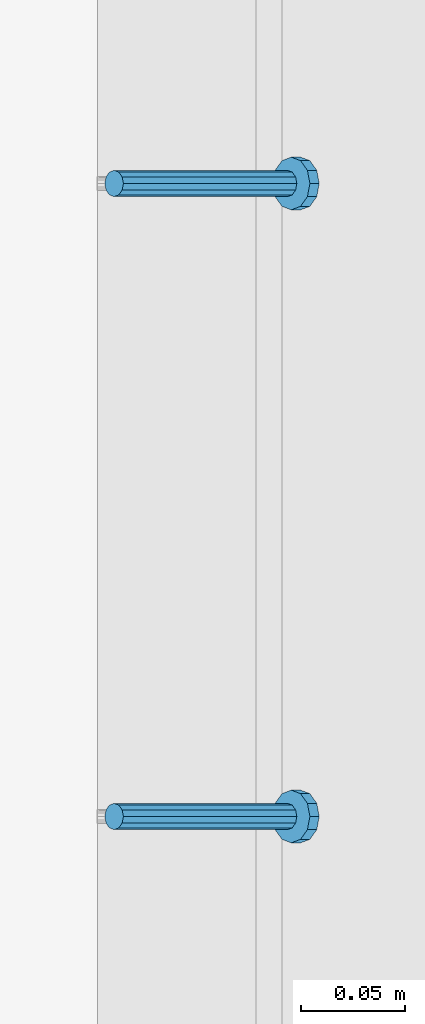
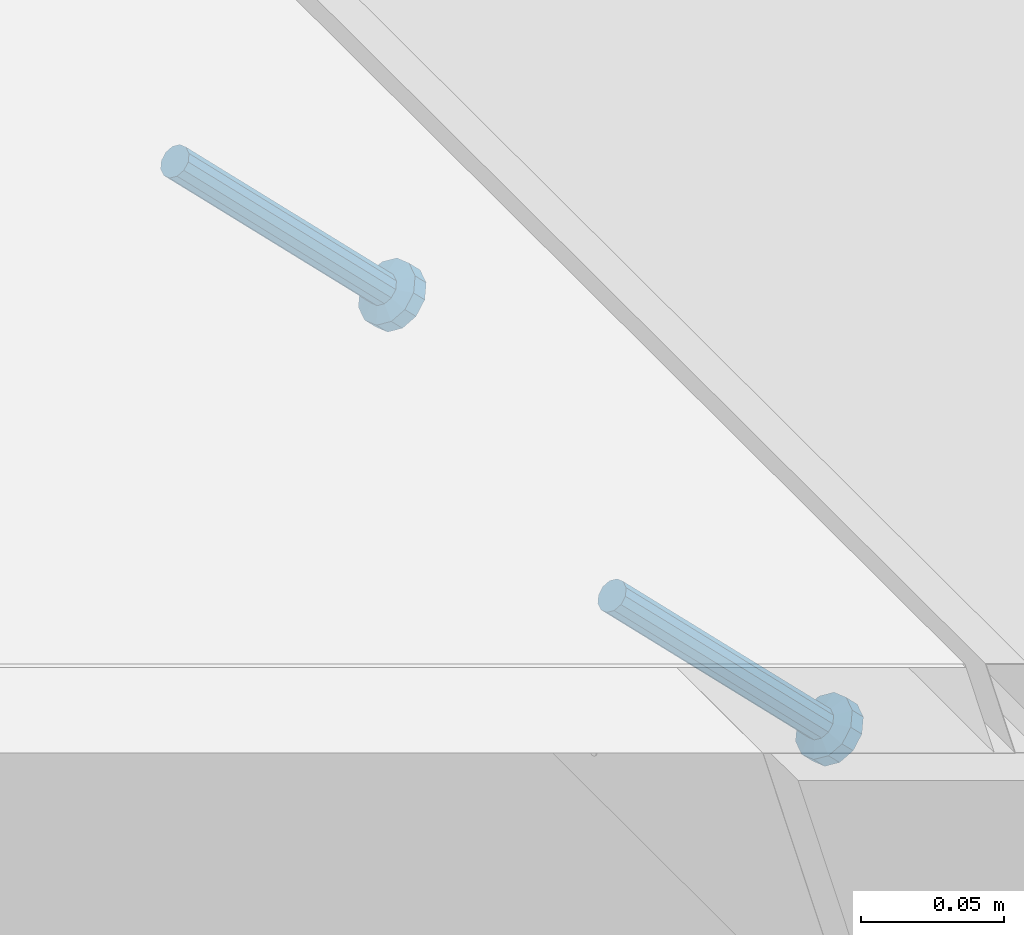
# One storey, part 2145 of 3843: 2 members, 1 element without a shape of its own.
"""IFC2X3 building model written with IfcOpenShell, lengths in millimetres."""

import ifcopenshell
import ifcopenshell.guid

model = None  # the IFC model being written
_history = None  # IfcOwnerHistory: only IFC2X3 demands one
_inside = {}  # id of a spatial element -> (the spatial element, [elements in it])
_under = {}  # id of a project, library or spatial element -> (it, [spatial elements below it])
_declared = {}  # id of a project -> (the project, [libraries it declares])
_typed = {}  # id of a type object -> (the type object, [elements of that type])
_made_of = {}  # id of a material, layer set ... -> (it, [elements and type objects made of it])


def new_model(schema):
    """Start an empty IFC model of exactly this schema.

    Asked for "IFC4X3", IfcOpenShell would pick the latest addendum, in which some entities
    have other attributes; the version numbers below select the first issue.
    IFC2X3 requires an IfcOwnerHistory on every rooted entity: one is made here for all.
    """
    global model, _history
    if schema == "IFC4X3":
        model = ifcopenshell.file(schema_version=(4, 3, 0, 0))
    else:
        model = ifcopenshell.file(schema=schema)
    _inside.clear()
    _under.clear()
    _declared.clear()
    _typed.clear()
    _made_of.clear()
    _history = None
    if model.schema == "IFC2X3":
        org = make("IfcOrganization", Name="unknown")
        user = make(
            "IfcPersonAndOrganization",
            ThePerson=make("IfcPerson", FamilyName="unknown"),
            TheOrganization=org,
        )
        app = make(
            "IfcApplication",
            ApplicationDeveloper=org,
            Version="unknown",
            ApplicationFullName="unknown",
            ApplicationIdentifier="unknown",
        )
        _history = make(
            "IfcOwnerHistory",
            OwningUser=user,
            OwningApplication=app,
            ChangeAction="ADDED",
            CreationDate=0,
        )
    return model


def make(cls, **values):
    """One entity of the class cls with the attributes given. An attribute that is None is left unset."""
    return model.create_entity(
        cls, **{name: value for name, value in values.items() if value is not None}
    )


def rooted(cls, **values):
    """An entity with a GlobalId (a new one), such as an element, a storey or a relation."""
    return make(cls, GlobalId=ifcopenshell.guid.new(), OwnerHistory=_history, **values)


def si_unit(unit_type, name, prefix=None):
    """IfcSIUnit, for example si_unit("LENGTHUNIT", "METRE", prefix="MILLI")."""
    return make("IfcSIUnit", UnitType=unit_type, Prefix=prefix, Name=name)


def assignment(units):
    """IfcUnitAssignment: the units of a project."""
    return None if units is None else make("IfcUnitAssignment", Units=units)


def point(xyz):
    """IfcCartesianPoint."""
    return None if xyz is None else make("IfcCartesianPoint", Coordinates=xyz)


def direction(xyz):
    """IfcDirection."""
    return None if xyz is None else make("IfcDirection", DirectionRatios=xyz)


def frame(location, z_axis=None, x_axis=None):
    """IfcAxis2Placement3D, a coordinate frame: its origin and axes. An axis left out is left unset."""
    return make(
        "IfcAxis2Placement3D",
        Location=point(location),
        Axis=direction(z_axis),
        RefDirection=direction(x_axis),
    )


def origin_with_axes():
    """The frame at (0, 0, 0) with the z axis (0, 0, 1) and the x axis (1, 0, 0) written out."""
    return frame((0.0, 0.0, 0.0), z_axis=(0.0, 0.0, 1.0), x_axis=(1.0, 0.0, 0.0))


def place(relative_to, where):
    """IfcLocalPlacement: puts the frame where relative to a parent placement (None: the world)."""
    return make(
        "IfcLocalPlacement", PlacementRelTo=relative_to, RelativePlacement=where
    )


def context(
    kind, dimensions, precision=None, world=None, true_north=None, identifier=None
):
    """IfcGeometricRepresentationContext, for example the 3D "Model" context."""
    return make(
        "IfcGeometricRepresentationContext",
        ContextIdentifier=identifier,
        ContextType=kind,
        CoordinateSpaceDimension=dimensions,
        Precision=precision,
        WorldCoordinateSystem=world,
        TrueNorth=true_north,
    )


def subcontext(parent, identifier, kind, view, scale=None):
    """IfcGeometricRepresentationSubContext, for example "Body" below "Model"."""
    return make(
        "IfcGeometricRepresentationSubContext",
        ContextIdentifier=identifier,
        ContextType=kind,
        ParentContext=parent,
        TargetScale=scale,
        TargetView=view,
    )


def project(units=None, contexts=None):
    """IfcProject with its units and contexts."""
    return rooted(
        "IfcProject",
        Name="project",
        RepresentationContexts=contexts,
        UnitsInContext=assignment(units),
    )


def spatial(cls, under=None, at=None, **own):
    """A site, building, storey or space (cls), placed at a placement, below another one or the project."""
    s = rooted(cls, ObjectPlacement=at, **own)
    if under is not None:
        _under.setdefault(under.id(), (under, []))[1].append(s)
    return s


def faces_of(points, faces, orient=None, outer=None):
    """IfcFace entities. A face is a list of loops; a loop is a list of indices into points, from 0.

    orient and outer hold one flag for each loop. By default every Orientation is true, the
    first loop of a face is its IfcFaceOuterBound and the others are IfcFaceBound.
    """
    made = []
    for i, loops in enumerate(faces):
        bounds = []
        for j, loop in enumerate(loops):
            is_outer = j == 0 if outer is None else outer[i][j]
            bounds.append(
                make(
                    "IfcFaceOuterBound" if is_outer else "IfcFaceBound",
                    Bound=make("IfcPolyLoop", Polygon=[points[k] for k in loop]),
                    Orientation=True if orient is None else orient[i][j],
                )
            )
        made.append(make("IfcFace", Bounds=bounds))
    return made


def faceted_brep(points, faces, orient=None, outer=None, voids=None):
    """IfcFacetedBrep: a solid bounded by flat faces; with voids (closed shells), ...WithVoids."""
    shared = [point(p) for p in points]
    hull = make("IfcClosedShell", CfsFaces=faces_of(shared, faces, orient, outer))
    if voids is None:
        return make("IfcFacetedBrep", Outer=hull)
    return make(
        "IfcFacetedBrepWithVoids",
        Outer=hull,
        Voids=[
            make(cls, CfsFaces=faces_of(shared, fs, o, b)) for cls, fs, o, b in voids
        ],
    )


def shape(context_of_items, identifier, shape_type, items):
    """IfcShapeRepresentation: the items that make up one representation, for example the "Body"."""
    return make(
        "IfcShapeRepresentation",
        ContextOfItems=context_of_items,
        RepresentationIdentifier=identifier,
        RepresentationType=shape_type,
        Items=items,
    )


def material(Name=None, Category=None):
    """IfcMaterial."""
    return make("IfcMaterial", Name=Name, Category=Category)


def made_of(thing, what):
    """Note that an element or type object is made of a material, layer set ...; save() writes the relation."""
    if what is not None:
        _made_of.setdefault(what.id(), (what, []))[1].append(thing)
    return thing


def type_object(cls, material=None, **own):
    """A type object (cls), such as IfcWallType, which elements share."""
    return made_of(rooted(cls, **own), material)


def element(
    cls,
    number,
    at=None,
    inside=None,
    cuts=None,
    type_object=None,
    material=None,
    context=None,
    identifier="Body",
    shape_type=None,
    held_by="IfcProductDefinitionShape",
    body=None,
    shapes=None,
    **own,
):
    """One element of the class cls, such as IfcWall. Its Tag is "e" and its number.

    at: its placement. inside: the storey or other place that contains it. cuts: it is an
    opening in that element (IfcRelVoidsElement). A single representation is given by context,
    identifier, shape_type and body (its items); several are given by shapes. held_by: the class
    of the entity that holds the representations. save() writes the other relations.
    """
    e = rooted(cls, Tag="e%d" % number, ObjectPlacement=at, **own)
    if body is not None:
        shapes = [shape(context, identifier, shape_type, body)]
    if shapes is not None:
        e.Representation = make(held_by, Representations=shapes)
    if inside is not None:
        _inside.setdefault(inside.id(), (inside, []))[1].append(e)
    if cuts is not None:
        rooted(
            "IfcRelVoidsElement", RelatingBuildingElement=cuts, RelatedOpeningElement=e
        )
    if type_object is not None:
        _typed.setdefault(type_object.id(), (type_object, []))[1].append(e)
    return made_of(e, material)


def aggregate(whole, parts):
    """IfcRelAggregates: a whole, such as a stair, and the parts it consists of."""
    return rooted("IfcRelAggregates", RelatingObject=whole, RelatedObjects=parts)


def save(model, path):
    """Write the relations noted so far, then the file.

    IfcRelAggregates (storeys below a building ...), IfcRelContainedInSpatialStructure (elements
    in a storey), IfcRelDefinesByType, IfcRelAssociatesMaterial and IfcRelDeclares: one each for
    every whole, place, type object, material and project.
    """
    for whole, parts in _under.values():
        aggregate(whole, parts)
    for where, things in _inside.values():
        rooted(
            "IfcRelContainedInSpatialStructure",
            RelatedElements=things,
            RelatingStructure=where,
        )
    for kind, things in _typed.values():
        rooted("IfcRelDefinesByType", RelatedObjects=things, RelatingType=kind)
    for what, things in _made_of.values():
        rooted("IfcRelAssociatesMaterial", RelatedObjects=things, RelatingMaterial=what)
    for by, libraries in _declared.values():
        rooted("IfcRelDeclares", RelatingContext=by, RelatedDefinitions=libraries)
    model.write(path)


model = new_model("IFC2X3")

# Units and contexts
model_context = context("Model", 3, precision=1e-05, world=origin_with_axes())
body_context = subcontext(model_context, "Body", "Model", "MODEL_VIEW")
ifc_project = project(units=[si_unit("LENGTHUNIT", "METRE", prefix="MILLI"), si_unit("AREAUNIT", "SQUARE_METRE"), si_unit("VOLUMEUNIT", "CUBIC_METRE"), si_unit("MASSUNIT", "GRAM", prefix="KILO"), si_unit("TIMEUNIT", "SECOND"), si_unit("PLANEANGLEUNIT", "RADIAN"), si_unit("SOLIDANGLEUNIT", "STERADIAN"), si_unit("THERMODYNAMICTEMPERATUREUNIT", "DEGREE_CELSIUS"), si_unit("LUMINOUSINTENSITYUNIT", "LUMEN")], contexts=[model_context])

# Site, building, storey
site_placement = place(None, origin_with_axes())
site = spatial("IfcSite", under=ifc_project, at=site_placement, CompositionType="ELEMENT")
building_placement = place(site_placement, origin_with_axes())
building = spatial("IfcBuilding", under=site, at=building_placement, Name="Undefined", CompositionType="ELEMENT")
storey_placement = place(building_placement, origin_with_axes())
storey = spatial("IfcBuildingStorey", under=building, at=storey_placement, Name="Undefined", CompositionType="ELEMENT", Elevation=0.0)

# Assembly, members
assembly_placement = place(storey_placement, origin_with_axes())
assembly = element("IfcElementAssembly", 1, at=assembly_placement, inside=storey, Name="EMBED_ANGLE", AssemblyPlace="NOTDEFINED", PredefinedType="RIGID_FRAME")
ifc_material = material(Name="STEEL/A108")
member_type = type_object("IfcMemberType", PredefinedType="NOTDEFINED")
member_1_placement = place(assembly_placement, frame((59660.5996396484, 31178.499609375, 30446.6625), z_axis=(0.0, 1.0, 0.0), x_axis=(0.707106781186548, 0.0, -0.707106781186548)))
member_1 = element("IfcMember", 2, at=member_1_placement, type_object=member_type, material=ifc_material, Name="HEADED STUD ANCHOR", context=body_context, shape_type="Brep", body=[
    faceted_brep([(7.27595761418343e-12, -3.18000006675175, 5.5), (0.0, -5.49999999998363, 3.1800000667572), (118.110000000976, -5.49999999999091, 3.1800000667572), (118.110000000983, -3.18000006675175, 5.5), (0.0, -6.3499999046162, 0.0), (118.110000000968, -6.34999990461256, 0.0), (0.0, -5.49999999998363, -3.1800000667572), (118.110000000976, -5.49999999999091, -3.1800000667572), (7.27595761418343e-12, -3.18000006675175, -5.5), (118.110000000983, -3.18000006675175, -5.5), (7.27595761418343e-12, -1.81898940354586e-12, -6.34999990463257), (118.110000000968, -1.81898940354586e-12, -6.34999990463257), (0.0, 3.18000006675175, -5.5), (118.110000000968, 3.18000006674811, -5.5), (7.27595761418343e-12, 5.49999999998363, -3.1800000667572), (118.110000000983, 5.49999999998363, -3.1800000667572), (7.27595761418343e-12, 6.3499999046162, 0.0), (118.110000000976, 6.34999990461256, 0.0), (7.27595761418343e-12, 5.49999999998363, 3.1800000667572), (118.110000000983, 5.49999999998363, 3.1800000667572), (0.0, 3.18000006675175, 5.5), (118.110000000968, 3.18000006674811, 5.5), (7.27595761418343e-12, -1.81898940354586e-12, 6.34999990463257), (118.110000000968, -1.81898940354586e-12, 6.34999990463257), (120.650000000991, -10.9899997710909, 6.34999990463257), (120.650000000998, -6.34000015257152, 10.9899997711182), (120.650000000991, -12.6999998092379, 0.0), (120.650000000991, -10.9899997710909, -6.34999990463257), (120.650000000998, -6.34000015257152, -10.9899997711182), (120.650000000991, -1.81898940354586e-12, -12.6899995803833), (120.650000000991, 6.34000015257152, -10.9899997711182), (120.650000000998, 10.9899997710909, -6.34999990463257), (120.650000000991, 12.6999998092342, 0.0), (120.650000000998, 10.9899997710909, 6.34999990463257), (120.650000000991, 6.34000015257152, 10.9899997711182), (120.650000000991, -1.81898940354586e-12, 12.6899995803833), (127.000000001048, -10.9899997710945, 6.34999990463257), (127.000000001048, -6.34000015257152, 10.9899997711182), (127.000000001048, -12.6999998092342, 0.0), (127.000000001048, -10.9899997710945, -6.34999990463257), (127.000000001048, -6.34000015257152, -10.9899997711182), (127.000000001048, 1.81898940354586e-12, -12.6899995803833), (127.000000001048, 6.34000015256788, -10.9899997711182), (127.000000001048, 10.9899997710909, -6.34999990463257), (127.000000001048, 12.6999998092379, 0.0), (127.000000001048, 10.9899997710909, 6.34999990463257), (127.000000001048, 6.34000015256788, 10.9899997711182), (127.000000001048, 1.81898940354586e-12, 12.6899995803833)], [[[0, 1, 2, 3]], [[1, 4, 5, 2]], [[4, 6, 7, 5]], [[6, 8, 9, 7]], [[8, 10, 11, 9]], [[10, 12, 13, 11]], [[12, 14, 15, 13]], [[14, 16, 17, 15]], [[16, 18, 19, 17]], [[18, 20, 21, 19]], [[20, 22, 23, 21]], [[22, 0, 3, 23]], [[22, 20, 18, 16, 14, 12, 10, 8, 6, 4, 1, 0]], [[3, 2, 24, 25]], [[2, 5, 26, 24]], [[5, 7, 27, 26]], [[7, 9, 28, 27]], [[9, 11, 29, 28]], [[11, 13, 30, 29]], [[13, 15, 31, 30]], [[15, 17, 32, 31]], [[17, 19, 33, 32]], [[19, 21, 34, 33]], [[21, 23, 35, 34]], [[23, 3, 25, 35]], [[25, 24, 36, 37]], [[24, 26, 38, 36]], [[26, 27, 39, 38]], [[27, 28, 40, 39]], [[28, 29, 41, 40]], [[29, 30, 42, 41]], [[30, 31, 43, 42]], [[31, 32, 44, 43]], [[32, 33, 45, 44]], [[33, 34, 46, 45]], [[34, 35, 47, 46]], [[35, 25, 37, 47]], [[38, 39, 40, 41, 42, 43, 44, 45, 46, 47, 37, 36]]]),
])
member_2_placement = place(assembly_placement, frame((59660.5996396484, 31483.299609375, 30446.6625), z_axis=(0.0, 1.0, 0.0), x_axis=(0.707106781186548, 0.0, -0.707106781186548)))
member_2 = element("IfcMember", 3, at=member_2_placement, type_object=member_type, material=ifc_material, Name="HEADED STUD ANCHOR", context=body_context, shape_type="Brep", body=[
    faceted_brep([(7.27595761418343e-12, -3.18000006675175, 5.5), (0.0, -5.49999999998363, 3.1800000667572), (118.110000000976, -5.49999999999091, 3.1800000667572), (118.110000000983, -3.18000006675175, 5.5), (0.0, -6.3499999046162, 0.0), (118.110000000968, -6.34999990461256, 0.0), (0.0, -5.49999999998363, -3.1800000667572), (118.110000000976, -5.49999999999091, -3.1800000667572), (7.27595761418343e-12, -3.18000006675175, -5.5), (118.110000000983, -3.18000006675175, -5.5), (7.27595761418343e-12, -1.81898940354586e-12, -6.34999990463257), (118.110000000968, -1.81898940354586e-12, -6.34999990463257), (0.0, 3.18000006675175, -5.5), (118.110000000968, 3.18000006674811, -5.5), (7.27595761418343e-12, 5.49999999998363, -3.1800000667572), (118.110000000983, 5.49999999998363, -3.1800000667572), (7.27595761418343e-12, 6.3499999046162, 0.0), (118.110000000976, 6.34999990461256, 0.0), (7.27595761418343e-12, 5.49999999998363, 3.1800000667572), (118.110000000983, 5.49999999998363, 3.1800000667572), (0.0, 3.18000006675175, 5.5), (118.110000000968, 3.18000006674811, 5.5), (7.27595761418343e-12, -1.81898940354586e-12, 6.34999990463257), (118.110000000968, -1.81898940354586e-12, 6.34999990463257), (120.650000000991, -10.9899997710909, 6.34999990463257), (120.650000000998, -6.34000015257152, 10.9899997711182), (120.650000000991, -12.6999998092379, 0.0), (120.650000000991, -10.9899997710909, -6.34999990463257), (120.650000000998, -6.34000015257152, -10.9899997711182), (120.650000000991, -1.81898940354586e-12, -12.6899995803833), (120.650000000991, 6.34000015257152, -10.9899997711182), (120.650000000998, 10.9899997710909, -6.34999990463257), (120.650000000991, 12.6999998092342, 0.0), (120.650000000998, 10.9899997710909, 6.34999990463257), (120.650000000991, 6.34000015257152, 10.9899997711182), (120.650000000991, -1.81898940354586e-12, 12.6899995803833), (127.000000001048, -10.9899997710945, 6.34999990463257), (127.000000001048, -6.34000015257152, 10.9899997711182), (127.000000001048, -12.6999998092342, 0.0), (127.000000001048, -10.9899997710945, -6.34999990463257), (127.000000001048, -6.34000015257152, -10.9899997711182), (127.000000001048, 1.81898940354586e-12, -12.6899995803833), (127.000000001048, 6.34000015256788, -10.9899997711182), (127.000000001048, 10.9899997710909, -6.34999990463257), (127.000000001048, 12.6999998092379, 0.0), (127.000000001048, 10.9899997710909, 6.34999990463257), (127.000000001048, 6.34000015256788, 10.9899997711182), (127.000000001048, 1.81898940354586e-12, 12.6899995803833)], [[[0, 1, 2, 3]], [[1, 4, 5, 2]], [[4, 6, 7, 5]], [[6, 8, 9, 7]], [[8, 10, 11, 9]], [[10, 12, 13, 11]], [[12, 14, 15, 13]], [[14, 16, 17, 15]], [[16, 18, 19, 17]], [[18, 20, 21, 19]], [[20, 22, 23, 21]], [[22, 0, 3, 23]], [[22, 20, 18, 16, 14, 12, 10, 8, 6, 4, 1, 0]], [[3, 2, 24, 25]], [[2, 5, 26, 24]], [[5, 7, 27, 26]], [[7, 9, 28, 27]], [[9, 11, 29, 28]], [[11, 13, 30, 29]], [[13, 15, 31, 30]], [[15, 17, 32, 31]], [[17, 19, 33, 32]], [[19, 21, 34, 33]], [[21, 23, 35, 34]], [[23, 3, 25, 35]], [[25, 24, 36, 37]], [[24, 26, 38, 36]], [[26, 27, 39, 38]], [[27, 28, 40, 39]], [[28, 29, 41, 40]], [[29, 30, 42, 41]], [[30, 31, 43, 42]], [[31, 32, 44, 43]], [[32, 33, 45, 44]], [[33, 34, 46, 45]], [[34, 35, 47, 46]], [[35, 25, 37, 47]], [[38, 39, 40, 41, 42, 43, 44, 45, 46, 47, 37, 36]]]),
])
aggregate(assembly, [member_1, member_2])

save(model, "model.ifc")
